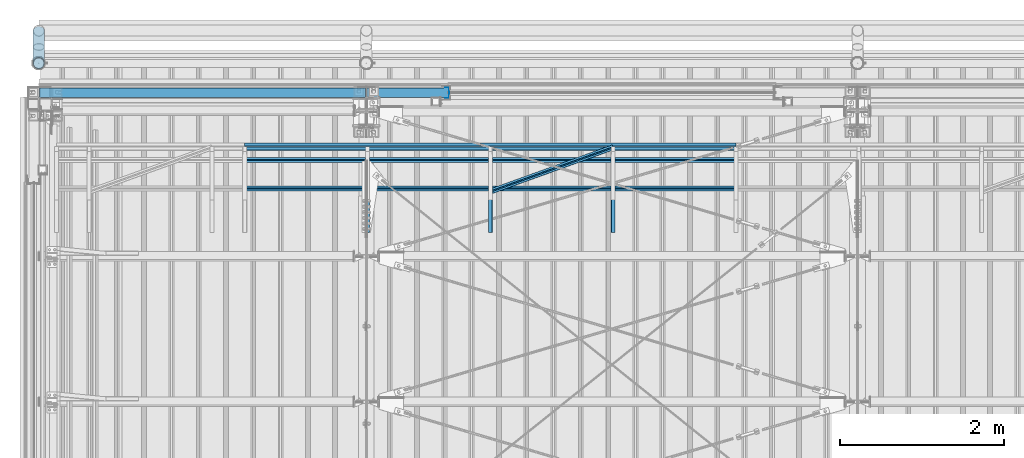
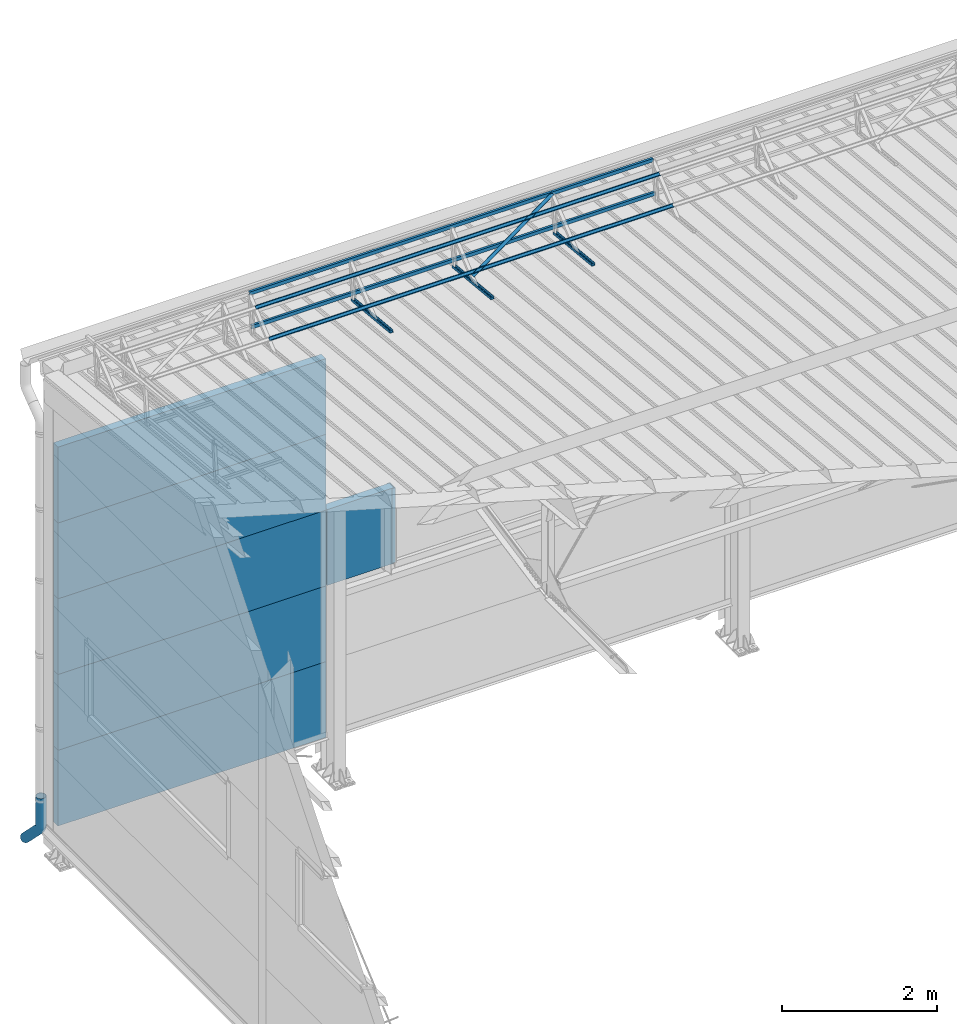
# One storey, part 52 of 709: 16 beams, 16 elements without a shape of their own.
"""IFC4 building model written with IfcOpenShell, lengths in millimetres."""

from ifc_helpers import new_model, entity, si_unit, direction, frame, origin_with_axes, place, context, subcontext, project, spatial, line, indexed_curve, outline, extrude, material, element, aggregate, save


model = new_model("IFC4")

# Units and contexts
model_context = context("Model", 3, precision=0.2, world=origin_with_axes(), true_north=direction((0.0, 1.0)))
body_context = subcontext(model_context, "Body", "Model", "MODEL_VIEW")
ifc_project = project(units=[si_unit("LENGTHUNIT", "METRE", prefix="MILLI"), si_unit("AREAUNIT", "SQUARE_METRE"), si_unit("VOLUMEUNIT", "CUBIC_METRE"), si_unit("MASSUNIT", "GRAM", prefix="KILO"), si_unit("TIMEUNIT", "SECOND"), si_unit("PLANEANGLEUNIT", "RADIAN"), si_unit("SOLIDANGLEUNIT", "STERADIAN"), si_unit("THERMODYNAMICTEMPERATUREUNIT", "DEGREE_CELSIUS"), si_unit("LUMINOUSINTENSITYUNIT", "LUMEN")], contexts=[model_context])

# Site, building, storey
site_placement = place(None, origin_with_axes())
site = spatial("IfcSite", under=ifc_project, at=site_placement, CompositionType="ELEMENT")
building_placement = place(site_placement, origin_with_axes())
building = spatial("IfcBuilding", under=site, at=building_placement, Name="Undefined", CompositionType="ELEMENT")
storey_placement = place(building_placement, origin_with_axes())
storey = spatial("IfcBuildingStorey", under=building, at=storey_placement, Name="Undefined", CompositionType="ELEMENT", Elevation=0.0)

# Assembly, beam
assembly_1_placement = place(storey_placement, frame((7015.0, 21349.29926, 7565.33969), z_axis=(0.0, 0.099503719, 0.9950371902), x_axis=(0.0, -0.9950371902, 0.099503719)))
assembly_1 = element("IfcElementAssembly", 1, at=assembly_1_placement, inside=storey)
ifc_material_1 = material(Name="Steel_Undefined", Category="STEEL")
beam_1_placement = place(assembly_1_placement, origin_with_axes())
beam_1 = element("IfcBeam", 2, at=beam_1_placement, material=ifc_material_1, ObjectType="601", context=body_context, shape_type="SolidModel", body=[
    extrude(outline(indexed_curve([(-20.0, -25.0), (20.0, -25.0), (20.0, -22.5), (-17.5, -22.5), (-17.5, 22.5), (20.0, 22.5), (20.0, 25.0), (-20.0, 25.0)], segments=[line(1, 2, 3, 4, 5, 6, 7, 8, 1)])), frame((0.0, 0.0, 0.0), z_axis=(-1.0, 0.0, 0.0), x_axis=(0.0, 0.0, 1.0)), (0.0, 0.0, -1.0), 1000.0),
])
aggregate(assembly_1, [beam_1])

assembly_2_placement = place(storey_placement, frame((5515.0, 21349.29926, 7565.33969), z_axis=(0.0, 0.099503719, 0.9950371902), x_axis=(0.0, -0.9950371902, 0.099503719)))
assembly_2 = element("IfcElementAssembly", 3, at=assembly_2_placement, inside=storey)
beam_2_placement = place(assembly_2_placement, origin_with_axes())
beam_2 = element("IfcBeam", 4, at=beam_2_placement, material=ifc_material_1, ObjectType="601", context=body_context, shape_type="SolidModel", body=[
    extrude(outline(indexed_curve([(-20.0, -25.0), (20.0, -25.0), (20.0, -22.5), (-17.5, -22.5), (-17.5, 22.5), (20.0, 22.5), (20.0, 25.0), (-20.0, 25.0)], segments=[line(1, 2, 3, 4, 5, 6, 7, 8, 1)])), frame((0.0, 0.0, 0.0), z_axis=(-1.0, 0.0, 0.0), x_axis=(0.0, 0.0, 1.0)), (0.0, 0.0, -1.0), 1000.0),
])
aggregate(assembly_2, [beam_2])

assembly_3_placement = place(storey_placement, frame((4015.0, 21349.29926, 7565.33969), z_axis=(0.0, 0.099503719, 0.9950371902), x_axis=(0.0, -0.9950371902, 0.099503719)))
assembly_3 = element("IfcElementAssembly", 5, at=assembly_3_placement, inside=storey)
beam_3_placement = place(assembly_3_placement, origin_with_axes())
beam_3 = element("IfcBeam", 6, at=beam_3_placement, material=ifc_material_1, ObjectType="601", context=body_context, shape_type="SolidModel", body=[
    extrude(outline(indexed_curve([(-20.0, -25.0), (20.0, -25.0), (20.0, -22.5), (-17.5, -22.5), (-17.5, 22.5), (20.0, 22.5), (20.0, 25.0), (-20.0, 25.0)], segments=[line(1, 2, 3, 4, 5, 6, 7, 8, 1)])), frame((0.0, 0.0, 0.0), z_axis=(-1.0, 0.0, 0.0), x_axis=(0.0, 0.0, 1.0)), (0.0, 0.0, -1.0), 1000.0),
])
aggregate(assembly_3, [beam_3])

assembly_4_placement = place(storey_placement, frame((8515.0, 21426.91216, 8140.47118), z_axis=(0.0, 0.9950371902, -0.099503719), x_axis=(-1.0, 0.0, 0.0)))
assembly_4 = element("IfcElementAssembly", 7, at=assembly_4_placement, inside=storey)
beam_4_placement = place(assembly_4_placement, origin_with_axes())
beam_4 = element("IfcBeam", 8, at=beam_4_placement, material=ifc_material_1, ObjectType="606", context=body_context, shape_type="SolidModel", body=[
    extrude(outline(indexed_curve([(-20.0, -25.0), (20.0, -25.0), (20.0, -22.5), (-17.5, -22.5), (-17.5, 22.5), (20.0, 22.5), (20.0, 25.0), (-20.0, 25.0)], segments=[line(1, 2, 3, 4, 5, 6, 7, 8, 1)])), frame((0.0, 0.0, 0.0), z_axis=(-1.0, 0.0, 0.0), x_axis=(0.0, 0.0, 1.0)), (0.0, 0.0, -1.0), 6000.0),
])
aggregate(assembly_4, [beam_4])

assembly_5_placement = place(storey_placement, frame((8515.0, 21377.1603, 7642.95259), z_axis=(0.0, 0.9950371902, -0.099503719), x_axis=(-1.0, 0.0, 0.0)))
assembly_5 = element("IfcElementAssembly", 9, at=assembly_5_placement, inside=storey)
beam_5_placement = place(assembly_5_placement, origin_with_axes())
beam_5 = element("IfcBeam", 10, at=beam_5_placement, material=ifc_material_1, ObjectType="606", context=body_context, shape_type="SolidModel", body=[
    extrude(outline(indexed_curve([(-20.0, -25.0), (20.0, -25.0), (20.0, -22.5), (-17.5, -22.5), (-17.5, 22.5), (20.0, 22.5), (20.0, 25.0), (-20.0, 25.0)], segments=[line(1, 2, 3, 4, 5, 6, 7, 8, 1)])), frame((0.0, 0.0, 0.0), z_axis=(-1.0, 0.0, 0.0), x_axis=(0.0, 0.0, 1.0)), (0.0, 0.0, -1.0), 6000.0),
])
aggregate(assembly_5, [beam_5])

assembly_6_placement = place(storey_placement, frame((8515.0, 21239.5552, 8031.29285), z_axis=(0.0, -0.6332377902, 0.7739572992), x_axis=(-1.0, 0.0, 0.0)))
assembly_6 = element("IfcElementAssembly", 11, at=assembly_6_placement, inside=storey)
beam_6_placement = place(assembly_6_placement, origin_with_axes())
beam_6 = element("IfcBeam", 12, at=beam_6_placement, material=ifc_material_1, ObjectType="606", context=body_context, shape_type="SolidModel", body=[
    extrude(outline(indexed_curve([(-20.0, -25.0), (20.0, -25.0), (20.0, -22.5), (-17.5, -22.5), (-17.5, 22.5), (20.0, 22.5), (20.0, 25.0), (-20.0, 25.0)], segments=[line(1, 2, 3, 4, 5, 6, 7, 8, 1)])), frame((0.0, 0.0, 0.0), z_axis=(-1.0, 0.0, 0.0), x_axis=(0.0, 0.0, 1.0)), (0.0, 0.0, -1.0), 6000.0),
])
aggregate(assembly_6, [beam_6])

assembly_7_placement = place(storey_placement, frame((8515.0, 20892.41357, 7747.26788), z_axis=(0.0, -0.6332377902, 0.7739572992), x_axis=(-1.0, 0.0, 0.0)))
assembly_7 = element("IfcElementAssembly", 13, at=assembly_7_placement, inside=storey)
beam_7_placement = place(assembly_7_placement, origin_with_axes())
beam_7 = element("IfcBeam", 14, at=beam_7_placement, material=ifc_material_1, ObjectType="606", context=body_context, shape_type="SolidModel", body=[
    extrude(outline(indexed_curve([(-20.0, -25.0), (20.0, -25.0), (20.0, -22.5), (-17.5, -22.5), (-17.5, 22.5), (20.0, 22.5), (20.0, 25.0), (-20.0, 25.0)], segments=[line(1, 2, 3, 4, 5, 6, 7, 8, 1)])), frame((0.0, 0.0, 0.0), z_axis=(-1.0, 0.0, 0.0), x_axis=(0.0, 0.0, 1.0)), (0.0, 0.0, -1.0), 6000.0),
])
aggregate(assembly_7, [beam_7])

assembly_8_placement = place(storey_placement, frame((7015.0, 21394.34666, 8157.9404), z_axis=(0.0, -0.6332377902, 0.7739572992), x_axis=(-0.9061831398, -0.3272952929, -0.2677870579)))
assembly_8 = element("IfcElementAssembly", 15, at=assembly_8_placement, inside=storey)
beam_8_placement = place(assembly_8_placement, origin_with_axes())
beam_8 = element("IfcBeam", 16, at=beam_8_placement, material=ifc_material_1, ObjectType="605", context=body_context, shape_type="SolidModel", body=[
    extrude(outline(indexed_curve([(-20.0, -25.0), (20.0, -25.0), (20.0, -22.5), (-17.5, -22.5), (-17.5, 22.5), (20.0, 22.5), (20.0, 25.0), (-20.0, 25.0)], segments=[line(1, 2, 3, 4, 5, 6, 7, 8, 1)])), frame((0.0, 0.0, 0.0), z_axis=(-1.0, 0.0, 0.0), x_axis=(0.0, 0.0, 1.0)), (0.0, 0.0, -1.0), 1655.29454),
])
aggregate(assembly_8, [beam_8])

assembly_9_placement = place(storey_placement, frame((10.0, 22060.0, 895.0), z_axis=(0.0, 0.0, -1.0), x_axis=(1.0, 0.0, 0.0)))
assembly_9 = element("IfcElementAssembly", 17, at=assembly_9_placement, inside=storey)
ifc_material_2 = material(Name="Insulation", Category="Insulation")
beam_9_placement = place(assembly_9_placement, origin_with_axes())
beam_9 = element("IfcBeam", 18, at=beam_9_placement, material=ifc_material_2, ObjectType="P-118", context=body_context, shape_type="SolidModel", body=[
    extrude(outline(indexed_curve([(-595.0, -60.0), (595.0, -60.0), (595.0, 60.0), (-595.0, 60.0)], segments=[line(1, 2, 3, 4, 1)])), frame((0.0, 0.0, 0.0), z_axis=(-1.0, 0.0, 0.0), x_axis=(0.0, 0.0, 1.0)), (0.0, 0.0, -1.0), 3980.0),
])
aggregate(assembly_9, [beam_9])

assembly_10_placement = place(storey_placement, frame((10.0, 22060.0, 2085.0), z_axis=(0.0, 0.0, -1.0), x_axis=(1.0, 0.0, 0.0)))
assembly_10 = element("IfcElementAssembly", 19, at=assembly_10_placement, inside=storey)
beam_10_placement = place(assembly_10_placement, origin_with_axes())
beam_10 = element("IfcBeam", 20, at=beam_10_placement, material=ifc_material_2, ObjectType="P-118", context=body_context, shape_type="SolidModel", body=[
    extrude(outline(indexed_curve([(-595.0, -60.0), (595.0, -60.0), (595.0, 60.0), (-595.0, 60.0)], segments=[line(1, 2, 3, 4, 1)])), frame((0.0, 0.0, 0.0), z_axis=(-1.0, 0.0, 0.0), x_axis=(0.0, 0.0, 1.0)), (0.0, 0.0, -1.0), 3980.0),
])
aggregate(assembly_10, [beam_10])

assembly_11_placement = place(storey_placement, frame((10.0, 22060.0, 3275.0), z_axis=(0.0, 0.0, -1.0), x_axis=(1.0, 0.0, 0.0)))
assembly_11 = element("IfcElementAssembly", 21, at=assembly_11_placement, inside=storey)
beam_11_placement = place(assembly_11_placement, origin_with_axes())
beam_11 = element("IfcBeam", 22, at=beam_11_placement, material=ifc_material_2, ObjectType="P-118", context=body_context, shape_type="SolidModel", body=[
    extrude(outline(indexed_curve([(-595.0, -60.0), (595.0, -60.0), (595.0, 60.0), (-595.0, 60.0)], segments=[line(1, 2, 3, 4, 1)])), frame((0.0, 0.0, 0.0), z_axis=(-1.0, 0.0, 0.0), x_axis=(0.0, 0.0, 1.0)), (0.0, 0.0, -1.0), 3980.0),
])
aggregate(assembly_11, [beam_11])

assembly_12_placement = place(storey_placement, frame((10.0, 22060.0, 4465.0), z_axis=(0.0, 0.0, -1.0), x_axis=(1.0, 0.0, 0.0)))
assembly_12 = element("IfcElementAssembly", 23, at=assembly_12_placement, inside=storey)
beam_12_placement = place(assembly_12_placement, origin_with_axes())
beam_12 = element("IfcBeam", 24, at=beam_12_placement, material=ifc_material_2, ObjectType="P-118", context=body_context, shape_type="SolidModel", body=[
    extrude(outline(indexed_curve([(-595.0, -60.0), (595.0, -60.0), (595.0, 60.0), (-595.0, 60.0)], segments=[line(1, 2, 3, 4, 1)])), frame((0.0, 0.0, 0.0), z_axis=(-1.0, 0.0, 0.0), x_axis=(0.0, 0.0, 1.0)), (0.0, 0.0, -1.0), 3980.0),
])
aggregate(assembly_12, [beam_12])

assembly_13_placement = place(storey_placement, frame((10.0, 22060.0, 5655.0), z_axis=(0.0, 0.0, -1.0), x_axis=(1.0, 0.0, 0.0)))
assembly_13 = element("IfcElementAssembly", 25, at=assembly_13_placement, inside=storey)
beam_13_placement = place(assembly_13_placement, origin_with_axes())
beam_13 = element("IfcBeam", 26, at=beam_13_placement, material=ifc_material_2, ObjectType="P-118", context=body_context, shape_type="SolidModel", body=[
    extrude(outline(indexed_curve([(-595.0, -60.0), (595.0, -60.0), (595.0, 60.0), (-595.0, 60.0)], segments=[line(1, 2, 3, 4, 1)])), frame((0.0, 0.0, 0.0), z_axis=(-1.0, 0.0, 0.0), x_axis=(0.0, 0.0, 1.0)), (0.0, 0.0, -1.0), 3980.0),
])
aggregate(assembly_13, [beam_13])

assembly_14_placement = place(storey_placement, frame((4010.0, 22060.0, 3275.0), z_axis=(0.0, 0.0, -1.0), x_axis=(1.0, 0.0, 0.0)))
assembly_14 = element("IfcElementAssembly", 27, at=assembly_14_placement, inside=storey)
beam_14_placement = place(assembly_14_placement, origin_with_axes())
beam_14 = element("IfcBeam", 28, at=beam_14_placement, material=ifc_material_2, ObjectType="P-110", context=body_context, shape_type="SolidModel", body=[
    extrude(outline(indexed_curve([(-595.0, -60.0), (595.0, -60.0), (595.0, 60.0), (-595.0, 60.0)], segments=[line(1, 2, 3, 4, 1)])), frame((0.0, 0.0, 0.0), z_axis=(-1.0, 0.0, 0.0), x_axis=(0.0, 0.0, 1.0)), (0.0, 0.0, -1.0), 990.0),
])
aggregate(assembly_14, [beam_14])

assembly_15_placement = place(storey_placement, frame((4990.0, 22060.0, 3870.0), z_axis=(0.0, -1.0, 0.0), x_axis=(0.0, 0.0, -1.0)))
assembly_15 = element("IfcElementAssembly", 29, at=assembly_15_placement, inside=storey)
beam_15_placement = place(assembly_15_placement, origin_with_axes())
beam_15 = element("IfcBeam", 30, at=beam_15_placement, material=ifc_material_1, context=body_context, shape_type="SolidModel", body=[
    extrude(outline(indexed_curve([(-70.0, -25.0), (-68.0, -25.0), (-68.0, 23.0), (68.0, 23.0), (68.0, -25.0), (70.0, -25.0), (70.0, 25.0), (-70.0, 25.0)], segments=[line(1, 2, 3, 4, 5, 6, 7, 8, 1)])), frame((0.0, 0.0, 0.0), z_axis=(-1.0, 0.0, 0.0), x_axis=(0.0, 0.0, 1.0)), (0.0, 0.0, -1.0), 1170.0),
])
aggregate(assembly_15, [beam_15])

assembly_16_placement = place(storey_placement, frame((0.0, 22420.0, 526.92297), z_axis=(1.0, 0.0, 0.0), x_axis=(0.0, 0.0, -1.0)))
assembly_16 = element("IfcElementAssembly", 31, at=assembly_16_placement, inside=storey)
beam_16_placement = place(assembly_16_placement, origin_with_axes())
beam_16 = element("IfcBeam", 32, at=beam_16_placement, material=ifc_material_1, ObjectType="617", context=body_context, shape_type="SolidModel", body=[
    entity("IfcSweptDiskSolid", entity("IfcIndexedPolyCurve", entity("IfcCartesianPointList3D", [[0.0, 0.0, 0.0], [448.2233, 0.0, 0.0], [496.05873, 9.51506, 0.0], [536.61165, 36.61165, 0.0], [900.0, 400.0, 0.0]]), [entity("IfcLineIndex", [1, 2]), entity("IfcArcIndex", [2, 3, 4]), entity("IfcLineIndex", [4, 5])]), 70.0, 65.0),
])
aggregate(assembly_16, [beam_16])

save(model, "model.ifc")
